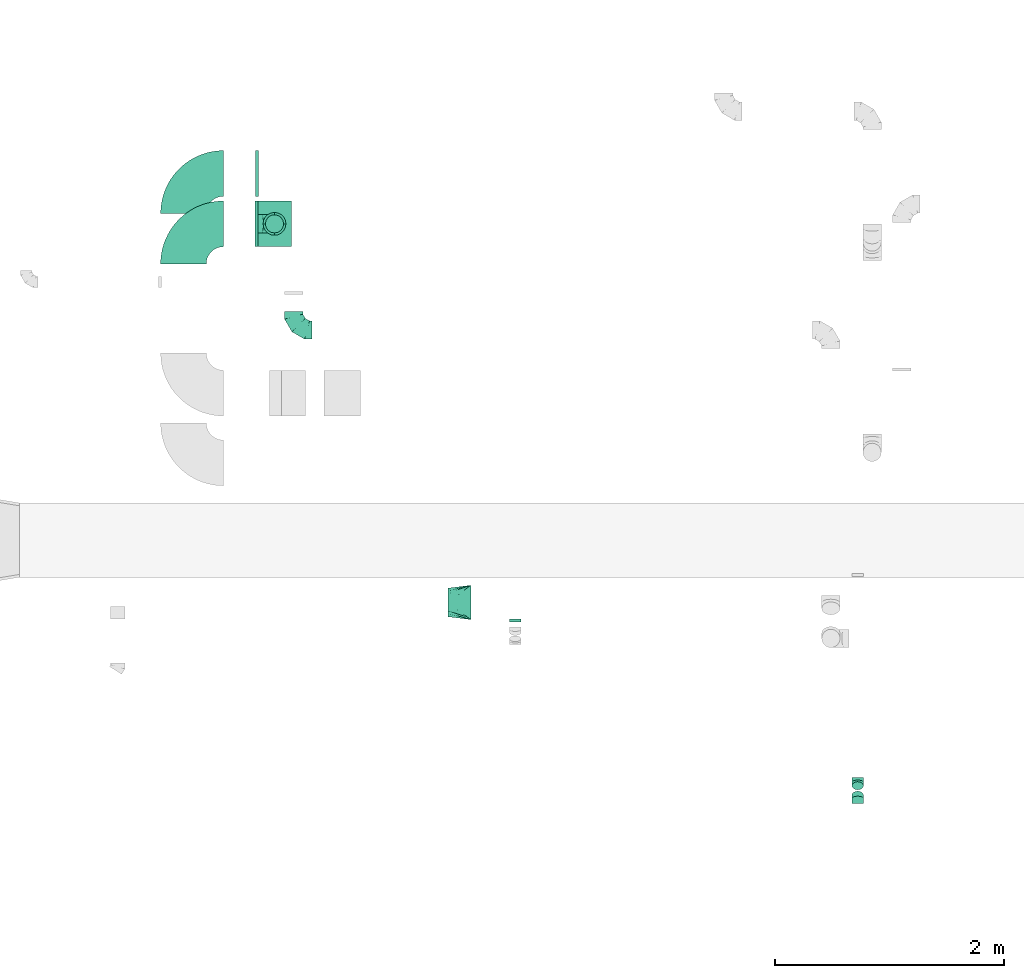
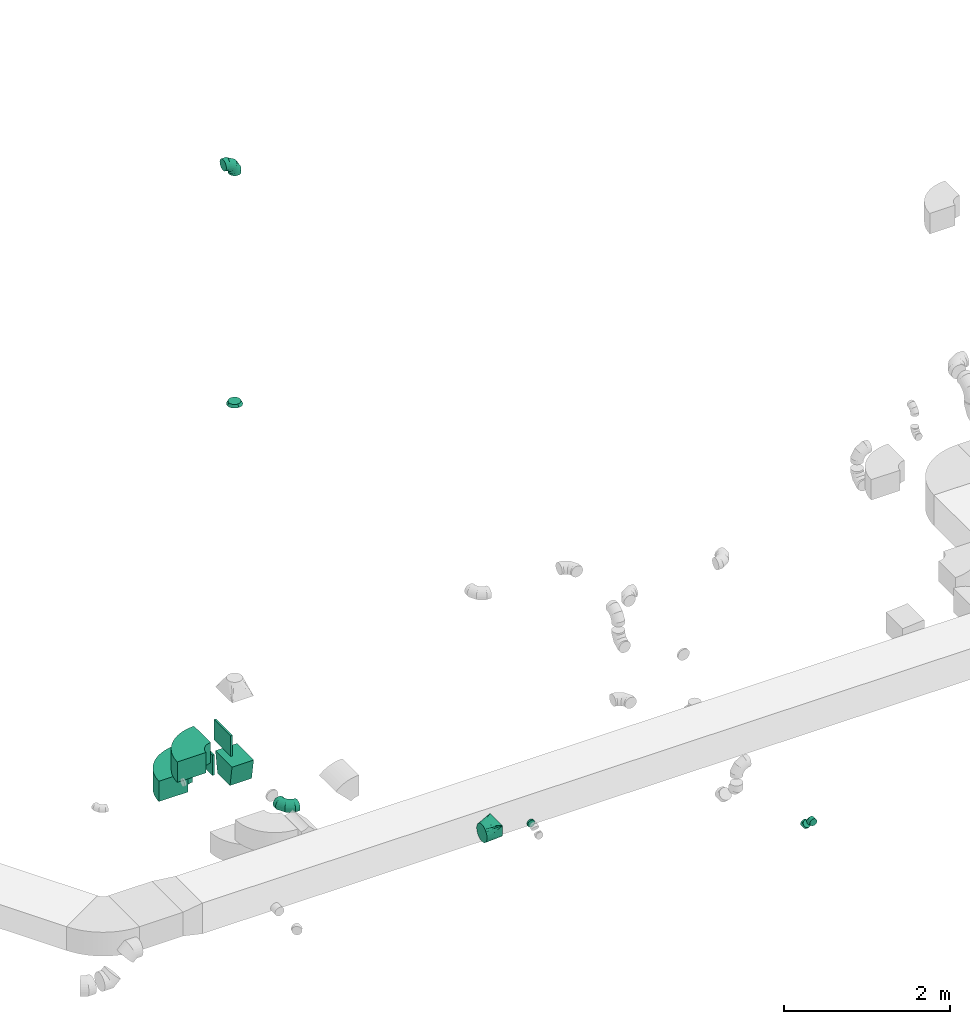
# One storey, part 6 of 44: 12 flow fittings.
"""IFC2X3 building model written with IfcOpenShell, lengths in millimetres."""

from ifc_helpers import new_model, entity, si_unit, converted_unit, derived_unit, direction, frame, frame_2d, origin, origin_2d_with_axis, place, context, subcontext, project, spatial, polyline, circle_curve, parameter, trimmed, segment, composite_curve, rectangle, outline, extrude, faceted_brep, source, transform, mapped, material, type_object, type_shapes, element, save


model = new_model("IFC2X3")

# Units and contexts
model_context = context("Model", 3, precision=0.01, world=origin(), true_north=direction((6.12303176911189e-17, 1.0)))
body_context = subcontext(model_context, "Body", "Model", "MODEL_VIEW")
ifc_project = project(units=[si_unit("LENGTHUNIT", "METRE", prefix="MILLI"), si_unit("AREAUNIT", "SQUARE_METRE"), si_unit("VOLUMEUNIT", "CUBIC_METRE"), converted_unit("PLANEANGLEUNIT", "DEGREE", entity("IfcRatioMeasure", 0.0174532925199433), si_unit("PLANEANGLEUNIT", "RADIAN"), dimensions=[0, 0, 0, 0, 0, 0, 0]), si_unit("MASSUNIT", "GRAM", prefix="KILO"), derived_unit("MASSDENSITYUNIT", [(si_unit("MASSUNIT", "GRAM", prefix="KILO"), 1), (si_unit("LENGTHUNIT", "METRE"), -3)]), derived_unit("MOMENTOFINERTIAUNIT", [(si_unit("LENGTHUNIT", "METRE"), 4)]), si_unit("TIMEUNIT", "SECOND"), si_unit("FREQUENCYUNIT", "HERTZ"), si_unit("THERMODYNAMICTEMPERATUREUNIT", "DEGREE_CELSIUS"), derived_unit("THERMALTRANSMITTANCEUNIT", [(si_unit("MASSUNIT", "GRAM", prefix="KILO"), 1), (si_unit("THERMODYNAMICTEMPERATUREUNIT", "KELVIN"), -1), (si_unit("TIMEUNIT", "SECOND"), -3)]), derived_unit("VOLUMETRICFLOWRATEUNIT", [(si_unit("LENGTHUNIT", "METRE"), 3), (si_unit("TIMEUNIT", "SECOND"), -1)]), derived_unit("MASSFLOWRATEUNIT", [(si_unit("MASSUNIT", "GRAM", prefix="KILO"), 1), (si_unit("TIMEUNIT", "SECOND"), -1)]), derived_unit("ROTATIONALFREQUENCYUNIT", [(si_unit("TIMEUNIT", "SECOND"), -1)]), si_unit("ELECTRICCURRENTUNIT", "AMPERE"), si_unit("ELECTRICVOLTAGEUNIT", "VOLT"), si_unit("POWERUNIT", "WATT"), si_unit("FORCEUNIT", "NEWTON", prefix="KILO"), si_unit("ILLUMINANCEUNIT", "LUX"), si_unit("LUMINOUSFLUXUNIT", "LUMEN"), si_unit("LUMINOUSINTENSITYUNIT", "CANDELA"), derived_unit("USERDEFINED", [(si_unit("MASSUNIT", "GRAM", prefix="KILO"), -1), (si_unit("LENGTHUNIT", "METRE"), -2), (si_unit("TIMEUNIT", "SECOND"), 3), (si_unit("LUMINOUSFLUXUNIT", "LUMEN"), 1)]), derived_unit("LINEARVELOCITYUNIT", [(si_unit("LENGTHUNIT", "METRE"), 1), (si_unit("TIMEUNIT", "SECOND"), -1)]), si_unit("PRESSUREUNIT", "PASCAL"), derived_unit("USERDEFINED", [(si_unit("LENGTHUNIT", "METRE"), -2), (si_unit("MASSUNIT", "GRAM", prefix="KILO"), 1), (si_unit("TIMEUNIT", "SECOND"), -2)]), derived_unit("LINEARFORCEUNIT", [(si_unit("MASSUNIT", "GRAM", prefix="KILO"), 1), (si_unit("LENGTHUNIT", "METRE"), 1), (si_unit("TIMEUNIT", "SECOND"), -2), (si_unit("LENGTHUNIT", "METRE"), -1)]), derived_unit("PLANARFORCEUNIT", [(si_unit("MASSUNIT", "GRAM", prefix="KILO"), 1), (si_unit("LENGTHUNIT", "METRE"), 1), (si_unit("TIMEUNIT", "SECOND"), -2), (si_unit("LENGTHUNIT", "METRE"), -2)])], contexts=[model_context])

# Site, building, storey
site_placement = place(None, origin())
site = spatial("IfcSite", under=ifc_project, at=site_placement, CompositionType="ELEMENT")
building_placement = place(site_placement, origin())
building = spatial("IfcBuilding", under=site, at=building_placement, CompositionType="ELEMENT")
storey_placement = place(building_placement, frame((0.0, 0.0, 15900.0)))
storey = spatial("IfcBuildingStorey", under=building, at=storey_placement, CompositionType="ELEMENT", Elevation=15900.0)

# Flow fittings
ifc_material = material()
duct_fitting_type_1 = type_object("IfcDuctFittingType", PredefinedType="NOTDEFINED", material=ifc_material)
shared_shape_1 = source(origin(), body_context, "Body", "SweptSolid", [
    extrude(rectangle(XDim=26.0960000000546, YDim=300.0, at=origin_2d_with_axis()), frame((6.95, 0.0, -200.0)), (0.0, 0.0, 1.0), 400.0),
])
type_shapes(duct_fitting_type_1, [shared_shape_1])
for number, where, z_axis, x_axis in (
    (1, (7873.56, 14800.63, 2750.0), (0.0, 1.0, 0.0), (-1.0, 0.0, 0.0)),
    (2, (7871.67, 14359.28, 3300.0), (0.0, 1.0, 0.0), (-1.0, 0.0, 0.0)),
):
    element("IfcFlowFitting", number, at=place(storey_placement, frame(where, z_axis=z_axis, x_axis=x_axis)), inside=storey, type_object=duct_fitting_type_1, material=ifc_material, context=body_context, shape_type="MappedRepresentation", body=[
        mapped(shared_shape_1, transform((0.0, 0.0, 0.0), scale=1.0)),
    ])
duct_fitting_type_2 = type_object("IfcDuctFittingType", PredefinedType="NOTDEFINED", material=ifc_material)
shared_shape_2 = source(origin(), body_context, "Body", "SweptSolid", [
    extrude(outline(polyline([(-180.84, -172.62), (123.3, -172.62), (172.62, 123.3), (-115.08, 221.94), (-180.84, -172.62)])), frame((150.0, -150.0, 0.0), z_axis=(0.0, 1.0, 0.0), x_axis=(0.986393923832128, 0.0, -0.16439898730545)), (0.0, 0.0, 1.0), 300.0),
])
type_shapes(duct_fitting_type_2, [shared_shape_2])
flow_fitting_1_placement = place(storey_placement, frame((8021.67, 14359.27, 2985.85), z_axis=(0.0, 1.0, -1.83537124904893e-05), x_axis=(0.0, -1.83537124904893e-05, -1.0)))
element("IfcFlowFitting", 3, at=flow_fitting_1_placement, inside=storey, type_object=duct_fitting_type_2, material=ifc_material, context=body_context, shape_type="MappedRepresentation", body=[
    mapped(shared_shape_2, transform((0.0, 0.0, 0.0), scale=1.0)),
])
duct_fitting_type_3 = type_object("IfcDuctFittingType", PredefinedType="NOTDEFINED", material=ifc_material)
shared_shape_3 = source(origin(), body_context, "Body", "Brep", [
    faceted_brep([(-160.0, 0.0, -80.0), (-160.0, -20.71, -77.27), (-160.0, -40.0, -69.28), (-160.0, -56.57, -56.57), (-160.0, -69.28, -40.0), (-160.0, -77.27, -20.71), (-160.0, -80.0, 0.0), (-160.0, -77.27, 20.71), (-160.0, -69.28, 40.0), (-160.0, -56.57, 56.57), (-160.0, -40.0, 69.28), (-160.0, -20.71, 77.27), (-160.0, 0.0, 80.0), (-160.0, 20.71, 77.27), (-160.0, 40.0, 69.28), (-160.0, 56.57, 56.57), (-160.0, 69.28, 40.0), (-160.0, 77.27, 20.71), (-160.0, 80.0, 0.0), (-160.0, 77.27, -20.71), (-160.0, 69.28, -40.0), (-160.0, 56.57, -56.57), (-160.0, 40.0, -69.28), (-160.0, 20.71, -77.27), (-122.68, 20.71, 77.27), (-127.85, 40.0, 69.28), (-117.13, 0.0, 80.0), (-132.29, 56.57, 56.57), (-137.83, 77.27, 20.71), (-138.56, 80.0, 0.0), (-135.69, 69.28, 40.0), (-135.69, 69.28, -40.0), (-132.29, 56.57, -56.57), (-137.83, 77.27, -20.71), (-122.68, 20.71, -77.27), (-117.13, 0.0, -80.0), (-127.85, 40.0, -69.28), (-111.58, -20.71, -77.27), (-106.41, -40.0, -69.28), (-101.97, -56.57, -56.57), (-98.56, -69.28, -40.0), (-96.42, -77.27, -20.71), (-95.69, -80.0, 0.0), (-96.42, -77.27, 20.71), (-98.56, -69.28, 40.0), (-101.97, -56.57, 56.57), (-106.41, -40.0, 69.28), (-111.58, -20.71, 77.27), (-58.03, 58.03, 77.27), (-72.15, 72.15, 69.28), (-42.87, 42.87, 80.0), (-84.28, 84.28, 56.57), (-93.59, 93.59, 40.0), (-99.44, 99.44, 20.71), (-101.44, 101.44, 0.0), (-99.44, 99.44, -20.71), (-93.59, 93.59, -40.0), (-84.28, 84.28, -56.57), (-58.03, 58.03, -77.27), (-42.87, 42.87, -80.0), (-72.15, 72.15, -69.28), (-27.71, 27.71, -77.27), (-13.59, 13.59, -69.28), (-1.46, 1.46, -56.57), (7.85, -7.85, -40.0), (13.7, -13.7, -20.71), (15.69, -15.69, 0.0), (13.7, -13.7, 20.71), (7.85, -7.85, 40.0), (-1.46, 1.46, 56.57), (-13.59, 13.59, 69.28), (-27.71, 27.71, 77.27), (-20.71, 122.68, 77.27), (-40.0, 127.85, 69.28), (0.0, 117.13, 80.0), (-56.57, 132.29, 56.57), (-69.28, 135.69, 40.0), (-77.27, 137.83, 20.71), (-80.0, 138.56, 0.0), (-77.27, 137.83, -20.71), (-69.28, 135.69, -40.0), (-56.57, 132.29, -56.57), (-20.71, 122.68, -77.27), (0.0, 117.13, -80.0), (-40.0, 127.85, -69.28), (20.71, 111.58, -77.27), (40.0, 106.41, -69.28), (56.57, 101.97, -56.57), (69.28, 98.56, -40.0), (77.27, 96.42, -20.71), (80.0, 95.69, 0.0), (77.27, 96.42, 20.71), (69.28, 98.56, 40.0), (56.57, 101.97, 56.57), (40.0, 106.41, 69.28), (20.71, 111.58, 77.27), (-20.71, 160.0, -77.27), (-40.0, 160.0, -69.28), (-56.57, 160.0, -56.57), (-69.28, 160.0, -40.0), (-77.27, 160.0, -20.71), (-80.0, 160.0, 0.0), (-77.27, 160.0, 20.71), (-69.28, 160.0, 40.0), (-56.57, 160.0, 56.57), (-40.0, 160.0, 69.28), (-20.71, 160.0, 77.27), (0.0, 160.0, 80.0), (20.71, 160.0, 77.27), (40.0, 160.0, 69.28), (56.57, 160.0, 56.57), (69.28, 160.0, 40.0), (77.27, 160.0, 20.71), (80.0, 160.0, 0.0), (77.27, 160.0, -20.71), (69.28, 160.0, -40.0), (56.57, 160.0, -56.57), (40.0, 160.0, -69.28), (20.71, 160.0, -77.27), (0.0, 160.0, -80.0)], [[[0, 1, 2, 3, 4, 5, 6, 7, 8, 9, 10, 11, 12, 13, 14, 15, 16, 17, 18, 19, 20, 21, 22, 23]], [[24, 25, 14, 13]], [[26, 24, 13, 12]], [[14, 25, 27, 15]], [[28, 29, 18, 17]], [[30, 28, 17, 16]], [[15, 27, 30, 16]], [[20, 31, 32, 21]], [[33, 31, 20, 19]], [[18, 29, 33, 19]], [[34, 35, 0, 23]], [[36, 34, 23, 22]], [[32, 36, 22, 21]], [[1, 0, 35, 37]], [[2, 1, 37, 38]], [[3, 2, 38, 39]], [[5, 4, 40, 41]], [[6, 5, 41, 42]], [[39, 40, 4, 3]], [[6, 42, 43, 7]], [[7, 43, 44, 8]], [[8, 44, 45, 9]], [[9, 45, 46, 10]], [[10, 46, 47, 11]], [[26, 12, 11, 47]], [[48, 49, 25, 24]], [[50, 48, 24, 26]], [[27, 25, 49, 51]], [[52, 53, 28, 30]], [[51, 52, 30, 27]], [[29, 28, 53, 54]], [[55, 56, 31, 33]], [[54, 55, 33, 29]], [[32, 31, 56, 57]], [[58, 59, 35, 34]], [[60, 58, 34, 36]], [[57, 60, 36, 32]], [[37, 35, 59, 61]], [[38, 37, 61, 62]], [[39, 38, 62, 63]], [[41, 40, 64, 65]], [[42, 41, 65, 66]], [[63, 64, 40, 39]], [[43, 42, 66, 67]], [[44, 43, 67, 68]], [[68, 69, 45, 44]], [[46, 45, 69, 70]], [[47, 46, 70, 71]], [[26, 47, 71, 50]], [[72, 73, 49, 48]], [[74, 72, 48, 50]], [[51, 49, 73, 75]], [[76, 77, 53, 52]], [[75, 76, 52, 51]], [[54, 53, 77, 78]], [[79, 80, 56, 55]], [[78, 79, 55, 54]], [[57, 56, 80, 81]], [[82, 83, 59, 58]], [[84, 82, 58, 60]], [[81, 84, 60, 57]], [[61, 59, 83, 85]], [[62, 61, 85, 86]], [[63, 62, 86, 87]], [[65, 64, 88, 89]], [[66, 65, 89, 90]], [[87, 88, 64, 63]], [[67, 66, 90, 91]], [[68, 67, 91, 92]], [[92, 93, 69, 68]], [[70, 69, 93, 94]], [[71, 70, 94, 95]], [[50, 71, 95, 74]], [[96, 97, 98, 99, 100, 101, 102, 103, 104, 105, 106, 107, 108, 109, 110, 111, 112, 113, 114, 115, 116, 117, 118, 119]], [[72, 74, 107, 106]], [[73, 72, 106, 105]], [[75, 73, 105, 104]], [[77, 76, 103, 102]], [[78, 77, 102, 101]], [[75, 104, 103, 76]], [[78, 101, 100, 79]], [[79, 100, 99, 80]], [[80, 99, 98, 81]], [[84, 97, 96, 82]], [[82, 96, 119, 83]], [[84, 81, 98, 97]], [[118, 117, 86, 85]], [[119, 118, 85, 83]], [[116, 87, 86, 117]], [[88, 115, 114, 89]], [[89, 114, 113, 90]], [[115, 88, 87, 116]], [[112, 111, 92, 91]], [[113, 112, 91, 90]], [[111, 110, 93, 92]], [[95, 94, 109, 108]], [[74, 95, 108, 107]], [[110, 109, 94, 93]]]),
])
type_shapes(duct_fitting_type_3, [shared_shape_3])
for number, where, z_axis, x_axis in (
    (4, (8189.69, 13430.35, 2710.0), (0.0, 0.0, 1.0), (0.0, -1.0, 0.0)),
    (5, (8021.67, 14359.29, 11700.0), (0.0, -1.0, 0.0), (0.0, 0.0, 1.0)),
):
    element("IfcFlowFitting", number, at=place(storey_placement, frame(where, z_axis=z_axis, x_axis=x_axis)), inside=storey, type_object=duct_fitting_type_3, material=ifc_material, context=body_context, shape_type="MappedRepresentation", body=[
        mapped(shared_shape_3, transform((0.0, 0.0, 0.0), scale=1.0)),
    ])
duct_fitting_type_4 = type_object("IfcDuctFittingType", PredefinedType="NOTDEFINED", material=ifc_material)
shared_shape_4 = source(origin(), body_context, "Body", "Brep", [
    faceted_brep([(-41.42, 0.0, -50.0), (-41.42, -12.94, -48.3), (-41.42, -25.0, -43.3), (-41.42, -35.36, -35.36), (-41.42, -43.3, -25.0), (-41.42, -48.3, -12.94), (-41.42, -50.0, 0.0), (-41.42, -48.3, 12.94), (-41.42, -43.3, 25.0), (-41.42, -35.36, 35.36), (-41.42, -25.0, 43.3), (-41.42, -12.94, 48.3), (-41.42, 0.0, 50.0), (-41.42, 12.94, 48.3), (-41.42, 25.0, 43.3), (-41.42, 35.36, 35.36), (-41.42, 43.3, 25.0), (-41.42, 48.3, 12.94), (-41.42, 50.0, 0.0), (-41.42, 48.3, -12.94), (-41.42, 43.3, -25.0), (-41.42, 35.36, -35.36), (-41.42, 25.0, -43.3), (-41.42, 12.94, -48.3), (-5.36, 12.94, 48.3), (-10.36, 25.0, 43.3), (0.0, 0.0, 50.0), (-14.64, 35.36, 35.36), (-20.0, 48.3, 12.94), (-20.71, 50.0, 0.0), (-17.94, 43.3, 25.0), (-17.94, 43.3, -25.0), (-14.64, 35.36, -35.36), (-20.0, 48.3, -12.94), (-5.36, 12.94, -48.3), (0.0, 0.0, -50.0), (-10.36, 25.0, -43.3), (5.36, -12.94, -48.3), (10.36, -25.0, -43.3), (14.64, -35.36, -35.36), (17.94, -43.3, -25.0), (20.0, -48.3, -12.94), (20.71, -50.0, 0.0), (20.0, -48.3, 12.94), (17.94, -43.3, 25.0), (14.64, -35.36, 35.36), (10.36, -25.0, 43.3), (5.36, -12.94, 48.3), (29.29, 29.29, 50.0), (20.14, 38.44, 48.3), (11.61, 46.97, 43.3), (4.29, 54.29, 35.36), (-1.33, 59.91, 25.0), (-4.86, 63.44, 12.94), (-6.07, 64.64, 0.0), (-4.86, 63.44, -12.94), (-1.33, 59.91, -25.0), (4.29, 54.29, -35.36), (11.61, 46.97, -43.3), (20.14, 38.44, -48.3), (29.29, 29.29, -50.0), (38.44, 20.14, -48.3), (46.97, 11.61, -43.3), (54.29, 4.29, -35.36), (59.91, -1.33, -25.0), (63.44, -4.86, -12.94), (64.64, -6.07, 0.0), (63.44, -4.86, 12.94), (59.91, -1.33, 25.0), (54.29, 4.29, 35.36), (46.97, 11.61, 43.3), (38.44, 20.14, 48.3)], [[[0, 1, 2, 3, 4, 5, 6, 7, 8, 9, 10, 11, 12, 13, 14, 15, 16, 17, 18, 19, 20, 21, 22, 23]], [[24, 25, 14, 13]], [[26, 24, 13, 12]], [[14, 25, 27, 15]], [[28, 29, 18, 17]], [[30, 28, 17, 16]], [[16, 15, 27, 30]], [[20, 31, 32, 21]], [[33, 31, 20, 19]], [[18, 29, 33, 19]], [[34, 35, 0, 23]], [[36, 34, 23, 22]], [[32, 36, 22, 21]], [[1, 0, 35, 37]], [[2, 1, 37, 38]], [[38, 39, 3, 2]], [[5, 4, 40, 41]], [[6, 5, 41, 42]], [[39, 40, 4, 3]], [[6, 42, 43, 7]], [[7, 43, 44, 8]], [[8, 44, 45, 9]], [[9, 45, 46, 10]], [[10, 46, 47, 11]], [[26, 12, 11, 47]], [[24, 26, 48, 49]], [[25, 24, 49, 50]], [[27, 25, 50, 51]], [[28, 30, 52, 53]], [[29, 28, 53, 54]], [[27, 51, 52, 30]], [[29, 54, 55, 33]], [[33, 55, 56, 31]], [[31, 56, 57, 32]], [[36, 58, 59, 34]], [[34, 59, 60, 35]], [[36, 32, 57, 58]], [[61, 62, 38, 37]], [[60, 61, 37, 35]], [[63, 39, 38, 62]], [[40, 64, 65, 41]], [[41, 65, 66, 42]], [[64, 40, 39, 63]], [[43, 42, 66, 67]], [[44, 43, 67, 68]], [[68, 69, 45, 44]], [[47, 46, 70, 71]], [[26, 47, 71, 48]], [[69, 70, 46, 45]], [[59, 58, 57, 56, 55, 54, 53, 52, 51, 50, 49, 48, 71, 70, 69, 68, 67, 66, 65, 64, 63, 62, 61, 60]]]),
])
type_shapes(duct_fitting_type_4, [shared_shape_4])
for number, where, z_axis, x_axis in (
    (6, (13124.76, 9472.03, 3150.0), (-1.0, 0.0, 0.0), (0.0, -1.0, 0.0)),
    (7, (13124.76, 9330.61, 3291.42), (1.0, 0.0, 0.0), (0.0, -0.707106781186493, 0.707106781186602)),
):
    element("IfcFlowFitting", number, at=place(storey_placement, frame(where, z_axis=z_axis, x_axis=x_axis)), inside=storey, type_object=duct_fitting_type_4, material=ifc_material, context=body_context, shape_type="MappedRepresentation", body=[
        mapped(shared_shape_4, transform((0.0, 0.0, 0.0), scale=1.0)),
    ])
duct_fitting_type_5 = type_object("IfcDuctFittingType", PredefinedType="NOTDEFINED", material=ifc_material)
shared_shape_5 = source(origin(), body_context, "Body", "Brep", [
    faceted_brep([(40.0, -73.91, 30.61), (40.0, -76.96, 15.31), (40.0, -80.0, 0.0), (40.0, -76.96, -15.31), (40.0, -73.91, -30.61), (40.0, -65.24, -43.59), (40.0, -56.57, -56.57), (40.0, -43.59, -65.24), (40.0, -30.61, -73.91), (40.0, -15.31, -76.96), (40.0, 0.0, -80.0), (40.0, 15.31, -76.96), (40.0, 30.61, -73.91), (40.0, 43.59, -65.24), (40.0, 56.57, -56.57), (40.0, 65.24, -43.59), (40.0, 73.91, -30.61), (40.0, 76.96, -15.31), (40.0, 80.0, 0.0), (40.0, 76.96, 15.31), (40.0, 73.91, 30.61), (40.0, 65.24, 43.59), (40.0, 56.57, 56.57), (40.0, 43.59, 65.24), (40.0, 30.61, 73.91), (40.0, 15.31, 76.96), (40.0, 0.0, 80.0), (40.0, -15.31, 76.96), (40.0, -30.61, 73.91), (40.0, -43.59, 65.24), (40.0, -56.57, 56.57), (40.0, -65.24, 43.59), (0.0, -100.0, 0.0), (0.0, -95.11, 30.9), (0.0, -80.9, 58.78), (0.0, -58.78, 80.9), (0.0, -30.9, 95.11), (0.0, 0.0, 100.0), (0.0, 30.9, 95.11), (0.0, 58.78, 80.9), (0.0, 80.9, 58.78), (0.0, 95.11, 30.9), (0.0, 100.0, 0.0), (0.0, 95.11, -30.9), (0.0, 80.9, -58.78), (0.0, 58.78, -80.9), (0.0, 30.9, -95.11), (0.0, 0.0, -100.0), (0.0, -30.9, -95.11), (0.0, -58.78, -80.9), (0.0, -80.9, -58.78), (0.0, -95.11, -30.9)], [[[0, 1, 2, 3, 4, 5, 6, 7, 8, 9, 10, 11, 12, 13, 14, 15, 16, 17, 18, 19, 20, 21, 22, 23, 24, 25, 26, 27, 28, 29, 30, 31]], [[32, 33, 34, 35, 36, 37, 38, 39, 40, 41, 42, 43, 44, 45, 46, 47, 48, 49, 50, 51]], [[37, 25, 38]], [[25, 24, 38]], [[24, 39, 38]], [[41, 20, 19]], [[25, 37, 26]], [[39, 24, 23, 22]], [[42, 19, 18]], [[20, 40, 22, 21]], [[41, 40, 20]], [[42, 41, 19]], [[22, 40, 39]], [[32, 1, 33]], [[1, 0, 33]], [[0, 34, 33]], [[36, 28, 27]], [[1, 32, 2]], [[34, 0, 31, 30]], [[37, 27, 26]], [[28, 35, 30, 29]], [[36, 35, 28]], [[37, 36, 27]], [[30, 35, 34]], [[47, 9, 48]], [[9, 8, 48]], [[8, 49, 48]], [[51, 4, 3]], [[9, 47, 10]], [[49, 8, 7, 6]], [[32, 3, 2]], [[4, 50, 6, 5]], [[51, 50, 4]], [[32, 51, 3]], [[6, 50, 49]], [[42, 17, 43]], [[17, 16, 43]], [[16, 44, 43]], [[46, 12, 11]], [[17, 42, 18]], [[44, 16, 15, 14]], [[47, 11, 10]], [[12, 45, 14, 13]], [[46, 45, 12]], [[47, 46, 11]], [[14, 45, 44]]]),
])
type_shapes(duct_fitting_type_5, [shared_shape_5])
flow_fitting_2_placement = place(storey_placement, frame((8021.67, 14359.29, 8145.85), z_axis=(1.0, 0.0, 0.0), x_axis=(0.0, 0.0, 1.0)))
element("IfcFlowFitting", 8, at=flow_fitting_2_placement, inside=storey, type_object=duct_fitting_type_5, material=ifc_material, context=body_context, shape_type="MappedRepresentation", body=[
    mapped(shared_shape_5, transform((0.0, 0.0, 0.0), scale=1.0)),
])
duct_fitting_type_6 = type_object("IfcDuctFittingType", PredefinedType="NOTDEFINED", material=ifc_material)
shared_shape_6 = source(origin(), body_context, "Body", "Brep", [
    faceted_brep([(20.0, 12.94, -48.3), (20.0, 25.0, -43.3), (20.0, 35.36, -35.36), (20.0, 43.3, -25.0), (20.0, 48.3, -12.94), (20.0, 50.0, 0.0), (20.0, 48.3, 12.94), (20.0, 43.3, 25.0), (20.0, 35.36, 35.36), (20.0, 25.0, 43.3), (20.0, 12.94, 48.3), (20.0, 0.0, 50.0), (20.0, -12.94, 48.3), (20.0, -25.0, 43.3), (20.0, -35.36, 35.36), (20.0, -43.3, 25.0), (20.0, -48.3, 12.94), (20.0, -50.0, 0.0), (20.0, -48.3, -12.94), (20.0, -43.3, -25.0), (20.0, -35.36, -35.36), (20.0, -25.0, -43.3), (20.0, -12.94, -48.3), (20.0, 0.0, -50.0), (0.0, 0.0, 50.0), (0.0, 12.94, 48.3), (-6.1, 12.94, 48.3), (-6.1, 0.0, 50.0), (0.0, 25.0, 43.3), (-6.1, 25.0, 43.3), (0.0, 35.36, 35.36), (-6.1, 35.36, 35.36), (0.0, 43.3, 25.0), (0.0, 48.3, 12.94), (-6.1, 48.3, 12.94), (-6.1, 43.3, 25.0), (0.0, 50.0, 0.0), (-6.1, 50.0, 0.0), (0.0, 48.3, -12.94), (-6.1, 48.3, -12.94), (0.0, 43.3, -25.0), (-6.1, 43.3, -25.0), (0.0, 35.36, -35.36), (-6.1, 35.36, -35.36), (0.0, 25.0, -43.3), (0.0, 12.94, -48.3), (-6.1, 12.94, -48.3), (-6.1, 25.0, -43.3), (0.0, 0.0, -50.0), (-6.1, 0.0, -50.0), (0.0, -12.94, -48.3), (-6.1, -12.94, -48.3), (0.0, -25.0, -43.3), (-6.1, -25.0, -43.3), (0.0, -35.36, -35.36), (-6.1, -35.36, -35.36), (0.0, -43.3, -25.0), (0.0, -48.3, -12.94), (-6.1, -48.3, -12.94), (-6.1, -43.3, -25.0), (0.0, -50.0, 0.0), (-6.1, -50.0, 0.0), (0.0, -48.3, 12.94), (-6.1, -48.3, 12.94), (0.0, -43.3, 25.0), (-6.1, -43.3, 25.0), (0.0, -35.36, 35.36), (-6.1, -35.36, 35.36), (0.0, -25.0, 43.3), (0.0, -12.94, 48.3), (-6.1, -12.94, 48.3), (-6.1, -25.0, 43.3)], [[[0, 1, 2, 3, 4, 5, 6, 7, 8, 9, 10, 11, 12, 13, 14, 15, 16, 17, 18, 19, 20, 21, 22, 23]], [[24, 11, 10, 25, 26, 27]], [[25, 10, 9, 28, 29, 26]], [[28, 9, 8, 30, 31, 29]], [[32, 7, 6, 33, 34, 35]], [[33, 6, 5, 36, 37, 34]], [[30, 8, 7, 32, 35, 31]], [[36, 5, 4, 38, 39, 37]], [[38, 4, 3, 40, 41, 39]], [[40, 3, 2, 42, 43, 41]], [[44, 1, 0, 45, 46, 47]], [[45, 0, 23, 48, 49, 46]], [[42, 2, 1, 44, 47, 43]], [[48, 23, 22, 50, 51, 49]], [[50, 22, 21, 52, 53, 51]], [[52, 21, 20, 54, 55, 53]], [[56, 19, 18, 57, 58, 59]], [[57, 18, 17, 60, 61, 58]], [[54, 20, 19, 56, 59, 55]], [[60, 17, 16, 62, 63, 61]], [[62, 16, 15, 64, 65, 63]], [[64, 15, 14, 66, 67, 65]], [[68, 13, 12, 69, 70, 71]], [[69, 12, 11, 24, 27, 70]], [[66, 14, 13, 68, 71, 67]], [[49, 51, 53, 55, 59, 58, 61, 63, 65, 67, 71, 70, 27, 26, 29, 31, 35, 34, 37, 39, 41, 43, 47, 46]]]),
])
type_shapes(duct_fitting_type_6, [shared_shape_6])
flow_fitting_3_placement = place(storey_placement, frame((10128.62, 10896.76, 3358.31), z_axis=(0.0, 0.0, -1.0), x_axis=(0.0, -1.0, 0.0)))
element("IfcFlowFitting", 9, at=flow_fitting_3_placement, inside=storey, type_object=duct_fitting_type_6, material=ifc_material, context=body_context, shape_type="MappedRepresentation", body=[
    mapped(shared_shape_6, transform((0.0, 0.0, 0.0), scale=1.0)),
])
duct_fitting_type_7 = type_object("IfcDuctFittingType", PredefinedType="NOTDEFINED", material=ifc_material)
shared_shape_7 = source(origin(), body_context, "Body", "Brep", [
    faceted_brep([(200.0, -73.47, -151.13), (200.0, -56.05, -160.0), (200.0, -38.63, -168.88), (200.0, -23.84, -171.22), (200.0, -11.92, -173.11), (200.0, -5.96, -174.06), (200.0, 0.0, -175.0), (200.0, 5.96, -174.06), (200.0, 11.92, -173.11), (200.0, 23.84, -171.22), (200.0, 38.63, -168.88), (200.0, 56.05, -160.0), (200.0, 73.47, -151.13), (200.0, 87.3, -137.3), (200.0, 101.13, -123.47), (200.0, 110.0, -106.05), (200.0, 118.88, -88.63), (200.0, 121.22, -73.84), (200.0, 123.11, -61.92), (200.0, 124.06, -55.96), (200.0, 125.0, -50.0), (200.0, 124.06, -44.04), (200.0, 123.11, -38.08), (200.0, 121.22, -26.16), (200.0, 118.88, -11.37), (200.0, 110.0, 6.05), (200.0, 101.13, 23.47), (200.0, 87.3, 37.3), (200.0, 73.47, 51.13), (200.0, 56.05, 60.0), (200.0, 38.63, 68.88), (200.0, 23.84, 71.22), (200.0, 11.92, 73.11), (200.0, 5.96, 74.06), (200.0, 0.0, 75.0), (200.0, -5.96, 74.06), (200.0, -11.92, 73.11), (200.0, -23.84, 71.22), (200.0, -38.63, 68.88), (200.0, -56.05, 60.0), (200.0, -73.47, 51.13), (200.0, -87.3, 37.3), (200.0, -101.13, 23.47), (200.0, -110.0, 6.05), (200.0, -118.88, -11.37), (200.0, -121.22, -26.16), (200.0, -123.11, -38.08), (200.0, -124.06, -44.04), (200.0, -125.0, -50.0), (200.0, -124.06, -55.96), (200.0, -123.11, -61.92), (200.0, -121.22, -73.84), (200.0, -118.88, -88.63), (200.0, -110.0, -106.05), (200.0, -101.13, -123.47), (200.0, -87.3, -137.3), (0.0, -150.0, 75.0), (0.0, 150.0, 75.0), (0.0, 150.0, -75.0), (0.0, -150.0, -75.0), (104.11, -71.91, 75.0), (100.0, -116.44, 59.29), (26.03, -130.48, 75.0), (78.09, -91.44, 75.0), (52.06, -110.96, 75.0), (188.01, -8.99, 75.0), (176.03, -17.98, 75.0), (152.06, -35.96, 75.0), (128.09, -53.94, 75.0), (52.06, -143.49, 42.46), (78.09, -140.24, 26.2), (104.11, -136.99, 9.93), (128.09, -133.99, -5.05), (152.06, -130.99, -20.04), (176.03, -128.0, -35.02), (188.01, -126.5, -42.51), (26.03, -146.75, 58.73), (26.03, -146.75, -71.75), (52.06, -143.49, -68.49), (78.09, -140.24, -65.24), (104.11, -136.99, -61.99), (128.09, -133.99, -58.99), (152.06, -130.99, -55.99), (176.03, -128.0, -53.0), (188.01, -126.5, -51.5), (100.0, -121.79, -103.94), (52.06, -110.96, -101.03), (78.09, -91.44, -114.04), (104.11, -71.91, -127.06), (128.09, -53.94, -139.04), (152.06, -35.96, -151.03), (176.03, -17.98, -163.01), (188.01, -8.99, -169.01), (26.03, -130.48, -88.01), (26.03, 130.48, -88.01), (52.06, 110.96, -101.03), (78.09, 91.44, -114.04), (104.11, 71.91, -127.06), (128.09, 53.94, -139.04), (152.06, 35.96, -151.03), (176.03, 17.98, -163.01), (188.01, 8.99, -169.01), (100.0, 116.44, -109.29), (52.06, 143.49, -68.49), (78.09, 140.24, -65.24), (104.11, 136.99, -61.99), (128.09, 133.99, -58.99), (152.06, 130.99, -55.99), (176.03, 128.0, -53.0), (188.01, 126.5, -51.5), (26.03, 146.75, -71.75), (26.03, 146.75, 58.73), (52.06, 143.49, 42.46), (78.09, 140.24, 26.2), (104.11, 136.99, 9.93), (128.09, 133.99, -5.05), (152.06, 130.99, -20.04), (176.03, 128.0, -35.02), (188.01, 126.5, -42.51), (100.0, 121.79, 53.94), (52.06, 110.96, 75.0), (78.09, 91.44, 75.0), (104.11, 71.91, 75.0), (128.09, 53.94, 75.0), (152.06, 35.96, 75.0), (176.03, 17.98, 75.0), (188.01, 8.99, 75.0), (26.03, 130.48, 75.0)], [[[0, 1, 2, 3, 4, 5, 6, 7, 8, 9, 10, 11, 12, 13, 14, 15, 16, 17, 18, 19, 20, 21, 22, 23, 24, 25, 26, 27, 28, 29, 30, 31, 32, 33, 34, 35, 36, 37, 38, 39, 40, 41, 42, 43, 44, 45, 46, 47, 48, 49, 50, 51, 52, 53, 54, 55]], [[56, 57, 58, 59]], [[60, 39, 38]], [[56, 61, 62]], [[39, 60, 63, 64]], [[65, 66, 67, 68, 60, 38, 37, 36, 35, 34]], [[62, 61, 40]], [[43, 69, 70, 71]], [[64, 40, 39]], [[44, 71, 72, 73, 74, 75, 48, 47, 46, 45]], [[42, 76, 69]], [[71, 44, 43]], [[61, 76, 41]], [[40, 64, 62]], [[76, 42, 41]], [[40, 61, 41]], [[61, 56, 76]], [[69, 43, 42]], [[75, 74, 73, 72, 71, 70, 69, 76, 56, 59, 77, 78, 79, 80, 81, 82, 83, 84, 48]], [[80, 53, 52]], [[59, 85, 77]], [[53, 80, 79, 78]], [[84, 83, 82, 81, 80, 52, 51, 50, 49, 48]], [[77, 85, 54]], [[1, 86, 87, 88]], [[78, 54, 53]], [[2, 88, 89, 90, 91, 92, 6, 5, 4, 3]], [[0, 93, 86]], [[88, 2, 1]], [[85, 93, 55]], [[54, 78, 77]], [[93, 0, 55]], [[54, 85, 55]], [[85, 59, 93]], [[86, 1, 0]], [[92, 91, 90, 89, 88, 87, 86, 93, 59, 58, 94, 95, 96, 97, 98, 99, 100, 101, 6]], [[97, 11, 10]], [[58, 102, 94]], [[11, 97, 96, 95]], [[101, 100, 99, 98, 97, 10, 9, 8, 7, 6]], [[94, 102, 12]], [[15, 103, 104, 105]], [[95, 12, 11]], [[16, 105, 106, 107, 108, 109, 20, 19, 18, 17]], [[14, 110, 103]], [[105, 16, 15]], [[102, 110, 13]], [[12, 95, 94]], [[110, 14, 13]], [[12, 102, 13]], [[102, 58, 110]], [[103, 15, 14]], [[58, 57, 111, 112, 113, 114, 115, 116, 117, 118, 20, 109, 108, 107, 106, 105, 104, 103, 110]], [[114, 25, 24]], [[57, 119, 111]], [[25, 114, 113, 112]], [[118, 117, 116, 115, 114, 24, 23, 22, 21, 20]], [[111, 119, 26]], [[29, 120, 121, 122]], [[112, 26, 25]], [[30, 122, 123, 124, 125, 126, 34, 33, 32, 31]], [[28, 127, 120]], [[122, 30, 29]], [[119, 127, 27]], [[26, 112, 111]], [[127, 28, 27]], [[26, 119, 27]], [[119, 57, 127]], [[120, 29, 28]], [[57, 56, 62, 64, 63, 60, 68, 67, 66, 65, 34, 126, 125, 124, 123, 122, 121, 120, 127]]]),
])
type_shapes(duct_fitting_type_7, [shared_shape_7])
flow_fitting_4_placement = place(storey_placement, frame((9739.35, 11046.76, 3375.0), z_axis=(-3.65497012526349e-08, 0.0, 1.0), x_axis=(-1.0, 0.0, -3.65497012526349e-08)))
element("IfcFlowFitting", 10, at=flow_fitting_4_placement, inside=storey, type_object=duct_fitting_type_7, material=ifc_material, context=body_context, shape_type="MappedRepresentation", body=[
    mapped(shared_shape_7, transform((0.0, 0.0, 0.0), scale=1.0)),
])
duct_fitting_type_8 = type_object("IfcDuctFittingType", PredefinedType="NOTDEFINED", material=ifc_material)
shared_shape_8 = source(origin(), body_context, "Body", "SweptSolid", [
    extrude(outline(composite_curve([segment(polyline([(-375.0, -175.0), (25.0, -175.0)]), True, "CONTINUOUS"), segment(trimmed(circle_curve(frame_2d((175.0, -175.0), x_axis=(0.0, 1.0)), 150.0), [parameter(0.0)], [parameter(90.0000000000001)], True, "PARAMETER"), False, "CONTINUOUS"), segment(polyline([(175.0, -25.0), (175.0, 375.0)]), True, "CONTINUOUS"), segment(trimmed(circle_curve(frame_2d((175.0, -175.0), x_axis=(0.0, 1.0)), 550.0), [parameter(0.0)], [parameter(90.0)], True, "PARAMETER"), True, "CONTINUOUS")], self_intersect=False)), frame((-175.0, 175.0, -150.0), z_axis=(0.0, 0.0, 1.0), x_axis=(-1.0, 0.0, 0.0)), (0.0, 0.0, 1.0), 300.0),
])
type_shapes(duct_fitting_type_8, [shared_shape_8])
for number, where, z_axis, x_axis in (
    (11, (7224.85, 14359.28, 3300.0), (0.0, 0.0, 1.0), (-1.0, 0.0, 0.0)),
    (12, (7225.26, 14800.56, 2750.0), (0.0, 0.0, 1.0), (-1.0, 0.0, 0.0)),
):
    element("IfcFlowFitting", number, at=place(storey_placement, frame(where, z_axis=z_axis, x_axis=x_axis)), inside=storey, type_object=duct_fitting_type_8, material=ifc_material, context=body_context, shape_type="MappedRepresentation", body=[
        mapped(shared_shape_8, transform((0.0, 0.0, 0.0), scale=1.0)),
    ])

save(model, "model.ifc")
